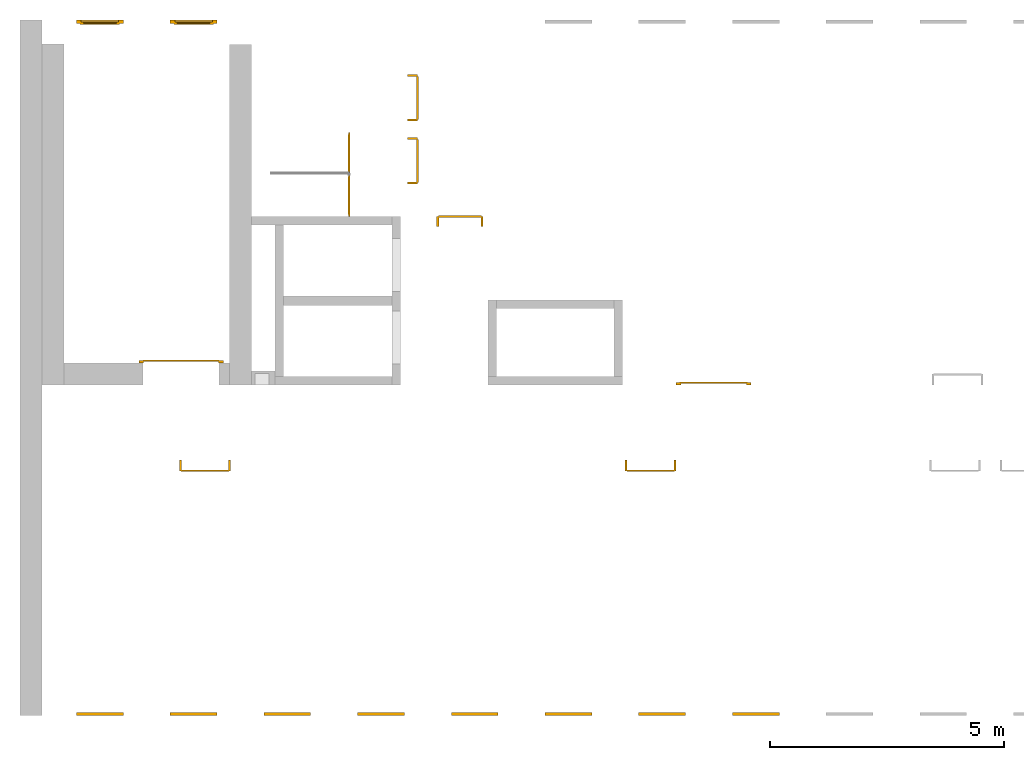
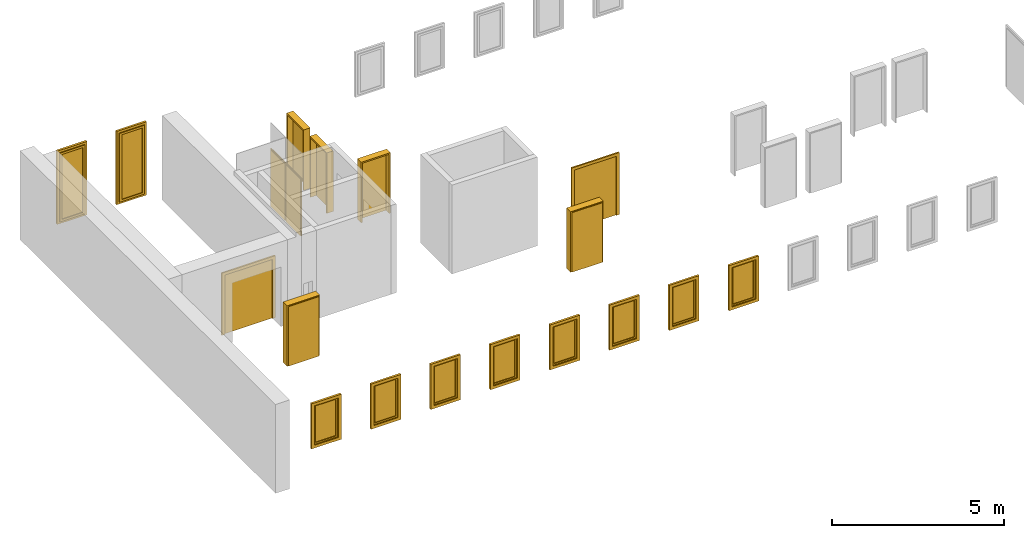
# One storey, part 2 of 3: 10 windows, 9 doors.
"""IFC4 building model written with IfcOpenShell, lengths in metres."""

from ifc_helpers import new_model, entity, si_unit, converted_unit, derived_unit, direction, frame, origin_with_axes, place, context, subcontext, project, spatial, polygons, source, transform, mapped, type_object, element, save


model = new_model("IFC4")

# Units and contexts
model_context = context("Model", 3, precision=1e-05, world=origin_with_axes(), true_north=direction((0.0, 1.0)))
body_context = subcontext(model_context, "Body", "Model", "MODEL_VIEW")
ifc_project = project(units=[si_unit("LENGTHUNIT", "METRE"), si_unit("AREAUNIT", "SQUARE_METRE"), si_unit("VOLUMEUNIT", "CUBIC_METRE"), converted_unit("PLANEANGLEUNIT", "DEGREE", entity("IfcPlaneAngleMeasure", 0.0174532925199433), si_unit("PLANEANGLEUNIT", "RADIAN"), dimensions=[0, 0, 0, 0, 0, 0, 0]), converted_unit("TIMEUNIT", "Year", entity("IfcTimeMeasure", 31557600.0), si_unit("TIMEUNIT", "SECOND"), dimensions=[0, 0, 1, 0, 0, 0, 0]), si_unit("MASSUNIT", "GRAM", prefix="KILO"), si_unit("THERMODYNAMICTEMPERATUREUNIT", "DEGREE_CELSIUS"), si_unit("LUMINOUSINTENSITYUNIT", "LUMEN"), si_unit("ENERGYUNIT", "JOULE", prefix="MEGA"), derived_unit("THERMALCONDUCTANCEUNIT", [(si_unit("POWERUNIT", "WATT"), 1), (si_unit("LENGTHUNIT", "METRE"), -1), (si_unit("THERMODYNAMICTEMPERATUREUNIT", "KELVIN"), -1)]), derived_unit("SPECIFICHEATCAPACITYUNIT", [(si_unit("ENERGYUNIT", "JOULE"), 1), (si_unit("MASSUNIT", "GRAM", prefix="KILO"), -1), (si_unit("THERMODYNAMICTEMPERATUREUNIT", "KELVIN"), -1)]), derived_unit("MASSDENSITYUNIT", [(si_unit("MASSUNIT", "GRAM", prefix="KILO"), 1), (si_unit("VOLUMEUNIT", "CUBIC_METRE"), -1)])], contexts=[model_context])

# Site, building, storey
site_placement = place(None, origin_with_axes())
site = spatial("IfcSite", under=ifc_project, at=site_placement, CompositionType="ELEMENT")
building_placement = place(None, origin_with_axes())
building = spatial("IfcBuilding", under=site, at=building_placement, CompositionType="ELEMENT")
storey_placement = place(None, frame((0.0, 0.0, 10.5), z_axis=(0.0, 0.0, 1.0), x_axis=(1.0, 0.0, 0.0)))
storey = spatial("IfcBuildingStorey", under=building, at=storey_placement, Name="3 OG", CompositionType="ELEMENT", Elevation=10.5)

# Windows
window_type = type_object("IfcWindowType", Name="1-27", PartitioningType="SINGLE_PANEL", PredefinedType="WINDOW")
shared_shape_1 = source(origin_with_axes(), body_context, "Body", "Tessellation", [
    polygons([(-0.5, -0.07, 0.0), (-0.5, 0.0, 0.0), (-0.4, 0.0, 0.1), (-0.4, -0.07, 0.1), (-0.5, -0.07, 1.6), (-0.5, 0.0, 1.6), (-0.4, 0.0, 1.5), (-0.4, -0.07, 1.5)], [[[1, 2, 3, 4]], [[5, 6, 2, 1]], [[2, 6, 7, 3]], [[4, 3, 7, 8]], [[1, 4, 8, 5]], [[8, 7, 6, 5]]], closed=True),
    polygons([(0.5, -0.07, 0.0), (0.5, 0.0, 0.0), (0.5, 0.0, 1.6), (0.5, -0.07, 1.6), (0.4, -0.07, 0.1), (0.4, 0.0, 0.1), (0.4, 0.0, 1.5), (0.4, -0.07, 1.5)], [[[1, 2, 3, 4]], [[5, 6, 2, 1]], [[2, 6, 7, 3]], [[4, 3, 7, 8]], [[1, 4, 8, 5]], [[8, 7, 6, 5]]], closed=True),
    polygons([(-0.5, -0.07, 0.0), (-0.5, 0.0, 0.0), (0.5, 0.0, 0.0), (0.5, -0.07, 0.0), (-0.4, -0.07, 0.1), (-0.4, 0.0, 0.1), (0.0, 0.0, 0.1), (0.4, 0.0, 0.1), (0.4, -0.07, 0.1), (0.0, -0.07, 0.1)], [[[1, 2, 3, 4]], [[5, 6, 2, 1]], [[2, 6, 7, 8, 3]], [[4, 3, 8, 9]], [[1, 4, 9, 10, 5]], [[10, 7, 6, 5]], [[9, 8, 7, 10]]], closed=True),
    polygons([(-0.5, -0.07, 1.6), (-0.5, 0.0, 1.6), (-0.4, 0.0, 1.5), (-0.4, -0.07, 1.5), (0.5, -0.07, 1.6), (0.5, 0.0, 1.6), (0.4, 0.0, 1.5), (0.0, 0.0, 1.5), (0.0, -0.07, 1.5), (0.4, -0.07, 1.5)], [[[1, 2, 3, 4]], [[5, 6, 2, 1]], [[2, 6, 7, 8, 3]], [[4, 3, 8, 9]], [[1, 4, 9, 10, 5]], [[10, 7, 6, 5]], [[9, 8, 7, 10]]], closed=True),
    polygons([(-0.42, 0.0, 0.08), (-0.42, 0.03, 0.08), (-0.35, 0.03, 0.15), (-0.35, 0.0, 0.15), (-0.42, 0.0, 1.52), (-0.42, 0.03, 1.52), (-0.35, 0.03, 1.45), (-0.35, 0.0, 1.45)], [[[1, 2, 3, 4]], [[5, 6, 2, 1]], [[2, 6, 7, 3]], [[4, 3, 7, 8]], [[1, 4, 8, 5]], [[8, 7, 6, 5]]], closed=True),
    polygons([(0.42, 0.0, 0.08), (0.35, 0.0, 0.15), (0.35, 0.03, 0.15), (0.42, 0.03, 0.08), (0.42, 0.0, 1.52), (0.35, 0.0, 1.45), (0.35, 0.03, 1.45), (0.42, 0.03, 1.52)], [[[1, 2, 3, 4]], [[1, 5, 6, 2]], [[2, 6, 7, 3]], [[4, 3, 7, 8]], [[5, 1, 4, 8]], [[6, 5, 8, 7]]], closed=True),
    polygons([(-0.42, 0.0, 0.08), (-0.42, 0.03, 0.08), (0.42, 0.03, 0.08), (0.42, 0.0, 0.08), (-0.35, 0.0, 0.15), (-0.35, 0.03, 0.15), (0.35, 0.03, 0.15), (0.35, 0.0, 0.15)], [[[1, 2, 3, 4]], [[5, 6, 2, 1]], [[2, 6, 7, 3]], [[4, 3, 7, 8]], [[1, 4, 8, 5]], [[8, 7, 6, 5]]], closed=True),
    polygons([(-0.42, 0.0, 1.52), (0.42, 0.0, 1.52), (0.42, 0.03, 1.52), (-0.42, 0.03, 1.52), (-0.35, 0.0, 1.45), (0.35, 0.0, 1.45), (0.35, 0.03, 1.45), (-0.35, 0.03, 1.45)], [[[1, 2, 3, 4]], [[1, 5, 6, 2]], [[2, 6, 7, 3]], [[4, 3, 7, 8]], [[5, 1, 4, 8]], [[6, 5, 8, 7]]], closed=True),
    polygons([(-0.4, -0.03, 0.1), (-0.4, 0.0, 0.1), (-0.35, 0.0, 0.15), (-0.35, -0.03, 0.15), (-0.4, -0.03, 1.5), (-0.4, 0.0, 1.5), (-0.35, 0.0, 1.45), (-0.35, -0.03, 1.45)], [[[1, 2, 3, 4]], [[5, 6, 2, 1]], [[2, 6, 7, 3]], [[4, 3, 7, 8]], [[1, 4, 8, 5]], [[8, 7, 6, 5]]], closed=True),
    polygons([(0.4, -0.03, 0.1), (0.35, -0.03, 0.15), (0.35, 0.0, 0.15), (0.4, 0.0, 0.1), (0.4, -0.03, 1.5), (0.35, -0.03, 1.45), (0.35, 0.0, 1.45), (0.4, 0.0, 1.5)], [[[1, 2, 3, 4]], [[1, 5, 6, 2]], [[2, 6, 7, 3]], [[4, 3, 7, 8]], [[5, 1, 4, 8]], [[6, 5, 8, 7]]], closed=True),
    polygons([(-0.4, -0.03, 0.1), (-0.4, 0.0, 0.1), (0.4, 0.0, 0.1), (0.4, -0.03, 0.1), (-0.35, -0.03, 0.15), (-0.35, 0.0, 0.15), (0.35, 0.0, 0.15), (0.35, -0.03, 0.15)], [[[1, 2, 3, 4]], [[5, 6, 2, 1]], [[2, 6, 7, 3]], [[4, 3, 7, 8]], [[1, 4, 8, 5]], [[8, 7, 6, 5]]], closed=True),
    polygons([(-0.4, -0.03, 1.5), (0.4, -0.03, 1.5), (0.4, 0.0, 1.5), (-0.4, 0.0, 1.5), (-0.35, -0.03, 1.45), (0.35, -0.03, 1.45), (0.35, 0.0, 1.45), (-0.35, 0.0, 1.45)], [[[1, 2, 3, 4]], [[1, 5, 6, 2]], [[2, 6, 7, 3]], [[4, 3, 7, 8]], [[5, 1, 4, 8]], [[6, 5, 8, 7]]], closed=True),
    polygons([(-0.35, -0.00500000000000001, 0.15), (-0.35, 0.00499999999999999, 0.15), (0.35, 0.00499999999999999, 0.15), (0.35, -0.00500000000000001, 0.15), (-0.35, -0.00500000000000001, 1.45), (-0.35, 0.00499999999999999, 1.45), (0.35, 0.00499999999999999, 1.45), (0.35, -0.00500000000000001, 1.45)], [[[1, 2, 3, 4]], [[5, 6, 2, 1]], [[2, 6, 7, 3]], [[4, 3, 7, 8]], [[1, 4, 8, 5]], [[8, 7, 6, 5]]], closed=True),
])
window_1_placement = place(None, frame((32.723, 0.0, 11.5), z_axis=(0.0, 0.0, 1.0), x_axis=(1.0, 0.0, 0.0)))
element("IfcWindow", 1, at=window_1_placement, inside=storey, type_object=window_type, Name="Fenster-001", OverallHeight=1.6, OverallWidth=1.0, context=body_context, shape_type="MappedRepresentation", body=[
    mapped(shared_shape_1, transform((0.5, 0.0700000000000033, 0.0))),
])
window_2_placement = place(None, frame((28.723, 0.0, 11.5), z_axis=(0.0, 0.0, 1.0), x_axis=(1.0, 0.0, 0.0)))
element("IfcWindow", 2, at=window_2_placement, inside=storey, type_object=window_type, Name="Fenster-001", OverallHeight=1.6, OverallWidth=1.0, context=body_context, shape_type="MappedRepresentation", body=[
    mapped(shared_shape_1, transform((0.5, 0.0700000000000037, 0.0))),
])
window_3_placement = place(None, frame((26.723, 0.0, 11.5), z_axis=(0.0, 0.0, 1.0), x_axis=(1.0, 0.0, 0.0)))
element("IfcWindow", 3, at=window_3_placement, inside=storey, type_object=window_type, Name="Fenster-001", OverallHeight=1.6, OverallWidth=1.0, context=body_context, shape_type="MappedRepresentation", body=[
    mapped(shared_shape_1, transform((0.5, 0.0700000000000041, 0.0))),
])
window_4_placement = place(None, frame((30.723, 0.0, 11.5), z_axis=(0.0, 0.0, 1.0), x_axis=(1.0, 0.0, 0.0)))
element("IfcWindow", 4, at=window_4_placement, inside=storey, type_object=window_type, Name="Fenster-001", OverallHeight=1.6, OverallWidth=1.0, context=body_context, shape_type="MappedRepresentation", body=[
    mapped(shared_shape_1, transform((0.5, 0.0700000000000035, 0.0))),
])
window_5_placement = place(None, frame((38.723, 0.0, 11.5), z_axis=(0.0, 0.0, 1.0), x_axis=(1.0, 0.0, 0.0)))
element("IfcWindow", 5, at=window_5_placement, inside=storey, type_object=window_type, Name="Fenster-001", OverallHeight=1.6, OverallWidth=1.0, context=body_context, shape_type="MappedRepresentation", body=[
    mapped(shared_shape_1, transform((0.5, 0.0700000000000025, 0.0))),
])
window_6_placement = place(None, frame((34.723, 0.0, 11.5), z_axis=(0.0, 0.0, 1.0), x_axis=(1.0, 0.0, 0.0)))
element("IfcWindow", 6, at=window_6_placement, inside=storey, type_object=window_type, Name="Fenster-001", OverallHeight=1.6, OverallWidth=1.0, context=body_context, shape_type="MappedRepresentation", body=[
    mapped(shared_shape_1, transform((0.5, 0.0700000000000031, 0.0))),
])
window_7_placement = place(None, frame((24.723, 0.0, 11.5), z_axis=(0.0, 0.0, 1.0), x_axis=(1.0, 0.0, 0.0)))
element("IfcWindow", 7, at=window_7_placement, inside=storey, type_object=window_type, Name="Fenster-001", OverallHeight=1.6, OverallWidth=1.0, context=body_context, shape_type="MappedRepresentation", body=[
    mapped(shared_shape_1, transform((0.5, 0.0700000000000043, 0.0))),
])
window_8_placement = place(None, frame((36.723, 0.0, 11.5), z_axis=(0.0, 0.0, 1.0), x_axis=(1.0, 0.0, 0.0)))
element("IfcWindow", 8, at=window_8_placement, inside=storey, type_object=window_type, Name="Fenster-001", OverallHeight=1.6, OverallWidth=1.0, context=body_context, shape_type="MappedRepresentation", body=[
    mapped(shared_shape_1, transform((0.5, 0.0700000000000028, 0.0))),
])

# Doors
door_type_1 = type_object("IfcDoorType", Name="27", OperationType="SINGLE_SWING_RIGHT", PredefinedType="DOOR")
shared_shape_2 = source(origin_with_axes(), body_context, "Body", "Tessellation", [
    polygons([(0.545, -0.2325, 0.0), (0.545, -0.025, 0.0), (0.545, -0.025, 2.145), (0.545, -0.2325, 2.145), (0.5, -0.2325, 0.0), (0.5, -0.025, 0.0), (0.5, -0.025, 2.1), (0.0551, -0.025, 2.1), (0.0001, -0.025, 2.1), (-0.5, -0.025, 2.1), (-0.5, -0.025, 0.0), (-0.545, -0.025, 0.0), (-0.545, -0.025, 2.145), (-0.545, -0.2325, 2.145), (-0.545, -0.2325, 0.0), (-0.5, -0.2325, 0.0), (-0.5, -0.2325, 2.1), (0.0001, -0.2325, 2.1), (0.0551, -0.2325, 2.1), (0.5, -0.2325, 2.1)], [[[1, 2, 3, 4]], [[5, 6, 2, 1]], [[2, 6, 7, 8, 9, 10, 11, 12, 13, 3]], [[4, 3, 13, 14]], [[1, 4, 14, 15, 16, 17, 18, 19, 20, 5]], [[20, 7, 6, 5]], [[19, 8, 7, 20]], [[18, 9, 8, 19]], [[17, 10, 9, 18]], [[16, 11, 10, 17]], [[15, 12, 11, 16]], [[14, 13, 12, 15]]], closed=True),
    polygons([(0.545, -0.025, 0.0), (0.545, 0.0, 0.0), (0.545, 0.0, 2.145), (0.545, -0.025, 2.145), (0.51, -0.025, 0.0), (0.51, 0.0, 0.0), (0.51, 0.0, 2.11), (0.0451, 0.0, 2.11), (0.0101, 0.0, 2.11), (-0.51, 0.0, 2.11), (-0.51, 0.0, 0.0), (-0.545, 0.0, 0.0), (-0.545, 0.0, 2.145), (-0.545, -0.025, 2.145), (-0.545, -0.025, 0.0), (-0.51, -0.025, 0.0), (-0.51, -0.025, 2.11), (0.0101, -0.025, 2.11), (0.0451, -0.025, 2.11), (0.51, -0.025, 2.11)], [[[1, 2, 3, 4]], [[5, 6, 2, 1]], [[2, 6, 7, 8, 9, 10, 11, 12, 13, 3]], [[4, 3, 13, 14]], [[1, 4, 14, 15, 16, 17, 18, 19, 20, 5]], [[20, 7, 6, 5]], [[19, 8, 7, 20]], [[18, 9, 8, 19]], [[17, 10, 9, 18]], [[16, 11, 10, 17]], [[15, 12, 11, 16]], [[14, 13, 12, 15]]], closed=True),
    polygons([(0.51, 0.015, 0.0), (-0.51, 0.015, 0.0), (-0.51, 0.015, 2.11), (0.51, 0.015, 2.11), (0.51, -0.025, 0.0), (-0.51, -0.025, 0.0), (-0.51, -0.025, 2.11), (0.51, -0.025, 2.11)], [[[1, 2, 3, 4]], [[2, 1, 5, 6]], [[3, 2, 6, 7]], [[4, 3, 7, 8]], [[1, 4, 8, 5]], [[6, 5, 8, 7]]], closed=True),
])
door_1_placement = place(None, frame((37.477, 5.45499994546755, 10.5), z_axis=(0.0, 0.0, 1.0), x_axis=(-1.0, 0.0, 0.0)))
element("IfcDoor", 9, at=door_1_placement, inside=storey, type_object=door_type_1, OverallHeight=2.145, OverallWidth=1.09, context=body_context, shape_type="MappedRepresentation", body=[
    mapped(shared_shape_2, transform((0.5, 0.2325, 0.0))),
])
door_type_2 = type_object("IfcDoorType", Name="27", OperationType="SINGLE_SWING_LEFT", PredefinedType="DOOR")
shared_shape_3 = source(origin_with_axes(), body_context, "Body", "Tessellation", [
    polygons([(-0.445, -0.025, 0.0), (-0.445, -0.025, 2.045), (-0.445, 0.0, 2.045), (-0.445, 0.0, 0.0), (-0.41, -0.025, 0.0), (-0.41, -0.025, 2.01), (-0.0451, -0.025, 2.01), (-0.0101, -0.025, 2.01), (0.41, -0.025, 2.01), (0.41, -0.025, 0.0), (0.445, -0.025, 0.0), (0.445, -0.025, 2.045), (0.445, 0.0, 2.045), (0.445, 0.0, 0.0), (0.41, 0.0, 0.0), (0.41, 0.0, 2.01), (-0.0101, 0.0, 2.01), (-0.0451, 0.0, 2.01), (-0.41, 0.0, 2.01), (-0.41, 0.0, 0.0)], [[[1, 2, 3, 4]], [[1, 5, 6, 7, 8, 9, 10, 11, 12, 2]], [[2, 12, 13, 3]], [[4, 3, 13, 14, 15, 16, 17, 18, 19, 20]], [[5, 1, 4, 20]], [[6, 5, 20, 19]], [[7, 6, 19, 18]], [[8, 7, 18, 17]], [[9, 8, 17, 16]], [[10, 9, 16, 15]], [[11, 10, 15, 14]], [[12, 11, 14, 13]]], closed=True),
    polygons([(-0.41, 0.015, 0.0), (-0.41, 0.015, 2.01), (0.41, 0.015, 2.01), (0.41, 0.015, 0.0), (-0.41, -0.025, 0.0), (-0.41, -0.025, 2.01), (0.41, -0.025, 2.01), (0.41, -0.025, 0.0)], [[[1, 2, 3, 4]], [[1, 5, 6, 2]], [[2, 6, 7, 3]], [[3, 7, 8, 4]], [[4, 8, 5, 1]], [[8, 7, 6, 5]]], closed=True),
])
door_2_placement = place(None, frame((30.553, 10.6999999454675, 10.55), z_axis=(0.0, 0.0, 1.0), x_axis=(0.0, 1.0, 0.0)))
element("IfcDoor", 10, at=door_2_placement, inside=storey, type_object=door_type_2, OverallHeight=2.095, OverallWidth=0.89, context=body_context, shape_type="MappedRepresentation", body=[
    mapped(shared_shape_3, transform((0.4, 0.0199999999999996, 0.0))),
])
door_type_3 = type_object("IfcDoorType", Name="2-Fl 27", OperationType="DOUBLE_DOOR_SINGLE_SWING", PredefinedType="DOOR")
shared_shape_4 = source(origin_with_axes(), body_context, "Body", "Tessellation", [
    polygons([(0.8, -0.05, 0.0), (0.8, -0.02, 0.0), (0.8, -0.02, 2.2), (0.8, -0.05, 2.2), (0.7, -0.05, 0.0), (0.7, -0.02, 0.0), (0.7, -0.02, 2.1), (0.1251, -0.02, 2.1), (0.0001, -0.02, 2.1), (-0.7, -0.02, 2.1), (-0.7, -0.02, 0.0), (-0.8, -0.02, 0.0), (-0.8, -0.02, 2.2), (-0.8, -0.05, 2.2), (-0.8, -0.05, 0.0), (-0.7, -0.05, 0.0), (-0.7, -0.05, 2.1), (0.0001, -0.05, 2.1), (0.1251, -0.05, 2.1), (0.7, -0.05, 2.1)], [[[1, 2, 3, 4]], [[5, 6, 2, 1]], [[2, 6, 7, 8, 9, 10, 11, 12, 13, 3]], [[4, 3, 13, 14]], [[1, 4, 14, 15, 16, 17, 18, 19, 20, 5]], [[20, 7, 6, 5]], [[19, 8, 7, 20]], [[18, 9, 8, 19]], [[17, 10, 9, 18]], [[16, 11, 10, 17]], [[15, 12, 11, 16]], [[14, 13, 12, 15]]], closed=True),
    polygons([(0.8, -0.02, 0.0), (0.8, 0.0, 0.0), (0.8, 0.0, 2.2), (0.8, -0.02, 2.2), (0.725, -0.02, 0.0), (0.725, 0.0, 0.0), (0.725, 0.0, 2.125), (0.1001, 0.0, 2.125), (0.0251, 0.0, 2.125), (-0.725, 0.0, 2.125), (-0.725, 0.0, 0.0), (-0.8, 0.0, 0.0), (-0.8, 0.0, 2.2), (-0.8, -0.02, 2.2), (-0.8, -0.02, 0.0), (-0.725, -0.02, 0.0), (-0.725, -0.02, 2.125), (0.0251, -0.02, 2.125), (0.1001, -0.02, 2.125), (0.725, -0.02, 2.125)], [[[1, 2, 3, 4]], [[5, 6, 2, 1]], [[2, 6, 7, 8, 9, 10, 11, 12, 13, 3]], [[4, 3, 13, 14]], [[1, 4, 14, 15, 16, 17, 18, 19, 20, 5]], [[20, 7, 6, 5]], [[19, 8, 7, 20]], [[18, 9, 8, 19]], [[17, 10, 9, 18]], [[16, 11, 10, 17]], [[15, 12, 11, 16]], [[14, 13, 12, 15]]], closed=True),
    polygons([(0.725, 0.02, 0.0), (0.000499999999999945, 0.02, 0.0), (0.000499999999999945, 0.02, 2.125), (0.725, 0.02, 2.125), (0.725, -0.02, 0.0), (0.000499999999999945, -0.02, 0.0), (0.000499999999999945, -0.02, 2.125), (0.725, -0.02, 2.125)], [[[1, 2, 3, 4]], [[2, 1, 5, 6]], [[3, 2, 6, 7]], [[4, 3, 7, 8]], [[1, 4, 8, 5]], [[6, 5, 8, 7]]], closed=True),
    polygons([(-0.725, 0.02, 0.0), (-0.725, 0.02, 2.125), (-0.000499999999999945, 0.02, 2.125), (-0.000499999999999945, 0.02, 0.0), (-0.725, -0.02, 0.0), (-0.725, -0.02, 2.125), (-0.000499999999999945, -0.02, 2.125), (-0.000499999999999945, -0.02, 0.0)], [[[1, 2, 3, 4]], [[1, 5, 6, 2]], [[2, 6, 7, 3]], [[3, 7, 8, 4]], [[4, 8, 5, 1]], [[8, 7, 6, 5]]], closed=True),
])
door_3_placement = place(None, frame((37.622, 7.05499994546756, 10.5), z_axis=(0.0, 0.0, 1.0), x_axis=(1.0, 0.0, 0.0)))
element("IfcDoor", 11, at=door_3_placement, inside=storey, type_object=door_type_3, OverallHeight=2.2, OverallWidth=1.6, context=body_context, shape_type="MappedRepresentation", body=[
    mapped(shared_shape_4, transform((0.700000000000003, 0.0499999999999998, 0.0))),
])
door_type_4 = type_object("IfcDoorType", OperationType="DOUBLE_DOOR_SINGLE_SWING", PredefinedType="DOOR")
shared_shape_5 = source(origin_with_axes(), body_context, "Body", "Tessellation", [
    polygons([(0.9, 0.0, 0.0), (0.9, 0.03, 0.0), (0.9, 0.03, 2.2), (0.9, 0.0, 2.2), (0.8, 0.0, 0.0), (0.8, 0.03, 0.0), (0.8, 0.03, 2.1), (0.1101, 0.03, 2.1), (0.0001, 0.03, 2.1), (-0.8, 0.03, 2.1), (-0.8, 0.03, 0.0), (-0.9, 0.03, 0.0), (-0.9, 0.03, 2.2), (-0.9, 0.0, 2.2), (-0.9, 0.0, 0.0), (-0.8, 0.0, 0.0), (-0.8, 0.0, 2.1), (0.0001, 0.0, 2.1), (0.1101, 0.0, 2.1), (0.8, 0.0, 2.1)], [[[1, 2, 3, 4]], [[5, 6, 2, 1]], [[2, 6, 7, 8, 9, 10, 11, 12, 13, 3]], [[4, 3, 13, 14]], [[1, 4, 14, 15, 16, 17, 18, 19, 20, 5]], [[20, 7, 6, 5]], [[19, 8, 7, 20]], [[18, 9, 8, 19]], [[17, 10, 9, 18]], [[16, 11, 10, 17]], [[15, 12, 11, 16]], [[14, 13, 12, 15]]], closed=True),
    polygons([(0.9, 0.03, 0.0), (0.9, 0.05, 0.0), (0.9, 0.05, 2.2), (0.9, 0.03, 2.2), (0.81, 0.03, 0.0), (0.81, 0.05, 0.0), (0.81, 0.05, 2.11), (0.1001, 0.05, 2.11), (0.0101, 0.05, 2.11), (-0.81, 0.05, 2.11), (-0.81, 0.05, 0.0), (-0.9, 0.05, 0.0), (-0.9, 0.05, 2.2), (-0.9, 0.03, 2.2), (-0.9, 0.03, 0.0), (-0.81, 0.03, 0.0), (-0.81, 0.03, 2.11), (0.0101, 0.03, 2.11), (0.1001, 0.03, 2.11), (0.81, 0.03, 2.11)], [[[1, 2, 3, 4]], [[5, 6, 2, 1]], [[2, 6, 7, 8, 9, 10, 11, 12, 13, 3]], [[4, 3, 13, 14]], [[1, 4, 14, 15, 16, 17, 18, 19, 20, 5]], [[20, 7, 6, 5]], [[19, 8, 7, 20]], [[18, 9, 8, 19]], [[17, 10, 9, 18]], [[16, 11, 10, 17]], [[15, 12, 11, 16]], [[14, 13, 12, 15]]], closed=True),
    polygons([(0.81, 0.07, 0.0), (0.000499999999999945, 0.07, 0.0), (0.000499999999999945, 0.07, 2.11), (0.81, 0.07, 2.11), (0.81, 0.03, 0.0), (0.000499999999999945, 0.03, 0.0), (0.000499999999999945, 0.03, 2.11), (0.81, 0.03, 2.11)], [[[1, 2, 3, 4]], [[2, 1, 5, 6]], [[3, 2, 6, 7]], [[4, 3, 7, 8]], [[1, 4, 8, 5]], [[6, 5, 8, 7]]], closed=True),
    polygons([(-0.81, 0.07, 0.0), (-0.81, 0.07, 2.11), (-0.000499999999999945, 0.07, 2.11), (-0.000499999999999945, 0.07, 0.0), (-0.81, 0.03, 0.0), (-0.81, 0.03, 2.11), (-0.000499999999999945, 0.03, 2.11), (-0.000499999999999945, 0.03, 0.0)], [[[1, 2, 3, 4]], [[1, 5, 6, 2]], [[2, 6, 7, 3]], [[3, 7, 8, 4]], [[4, 8, 5, 1]], [[8, 7, 6, 5]]], closed=True),
])
door_4_placement = place(None, frame((26.158, 7.52499994546755, 10.5), z_axis=(0.0, 0.0, 1.0), x_axis=(1.0, 0.0, 0.0)))
element("IfcDoor", 12, at=door_4_placement, inside=storey, type_object=door_type_4, OverallHeight=2.11, OverallWidth=1.62, context=body_context, shape_type="MappedRepresentation", body=[
    mapped(shared_shape_5, transform((0.800000000000001, 0.0, 0.0))),
])
shared_shape_6 = source(origin_with_axes(), body_context, "Body", "Tessellation", [
    polygons([(-0.495, -0.218, 0.0), (-0.495, -0.218, 2.145), (-0.495, -0.025, 2.145), (-0.495, -0.025, 0.0), (-0.45, -0.218, 0.0), (-0.45, -0.218, 2.1), (-0.0551, -0.218, 2.1), (-0.0001, -0.218, 2.1), (0.45, -0.218, 2.1), (0.45, -0.218, 0.0), (0.495, -0.218, 0.0), (0.495, -0.218, 2.145), (0.495, -0.025, 2.145), (0.495, -0.025, 0.0), (0.45, -0.025, 0.0), (0.45, -0.025, 2.1), (-0.0001, -0.025, 2.1), (-0.0551, -0.025, 2.1), (-0.45, -0.025, 2.1), (-0.45, -0.025, 0.0)], [[[1, 2, 3, 4]], [[1, 5, 6, 7, 8, 9, 10, 11, 12, 2]], [[2, 12, 13, 3]], [[4, 3, 13, 14, 15, 16, 17, 18, 19, 20]], [[5, 1, 4, 20]], [[6, 5, 20, 19]], [[7, 6, 19, 18]], [[8, 7, 18, 17]], [[9, 8, 17, 16]], [[10, 9, 16, 15]], [[11, 10, 15, 14]], [[12, 11, 14, 13]]], closed=True),
    polygons([(-0.495, -0.025, 0.0), (-0.495, -0.025, 2.145), (-0.495, 0.0, 2.145), (-0.495, 0.0, 0.0), (-0.46, -0.025, 0.0), (-0.46, -0.025, 2.11), (-0.0451, -0.025, 2.11), (-0.0101, -0.025, 2.11), (0.46, -0.025, 2.11), (0.46, -0.025, 0.0), (0.495, -0.025, 0.0), (0.495, -0.025, 2.145), (0.495, 0.0, 2.145), (0.495, 0.0, 0.0), (0.46, 0.0, 0.0), (0.46, 0.0, 2.11), (-0.0101, 0.0, 2.11), (-0.0451, 0.0, 2.11), (-0.46, 0.0, 2.11), (-0.46, 0.0, 0.0)], [[[1, 2, 3, 4]], [[1, 5, 6, 7, 8, 9, 10, 11, 12, 2]], [[2, 12, 13, 3]], [[4, 3, 13, 14, 15, 16, 17, 18, 19, 20]], [[5, 1, 4, 20]], [[6, 5, 20, 19]], [[7, 6, 19, 18]], [[8, 7, 18, 17]], [[9, 8, 17, 16]], [[10, 9, 16, 15]], [[11, 10, 15, 14]], [[12, 11, 14, 13]]], closed=True),
    polygons([(-0.46, 0.015, 0.0), (-0.46, 0.015, 2.11), (0.46, 0.015, 2.11), (0.46, 0.015, 0.0), (-0.46, -0.025, 0.0), (-0.46, -0.025, 2.11), (0.46, -0.025, 2.11), (0.46, -0.025, 0.0)], [[[1, 2, 3, 4]], [[1, 5, 6, 2]], [[2, 6, 7, 3]], [[3, 7, 8, 4]], [[4, 8, 5, 1]], [[8, 7, 6, 5]]], closed=True),
])
for number, where, z_axis, x_axis in (
    (13, (32.005, 13.6354999136732, 10.5), (0.0, 0.0, 1.0), (0.0, -1.0, 0.0)),
    (14, (32.005, 12.2904999136732, 10.5), (0.0, 0.0, 1.0), (0.0, -1.0, 0.0)),
):
    element("IfcDoor", number, at=place(None, frame(where, z_axis=z_axis, x_axis=x_axis)), inside=storey, type_object=door_type_2, OverallHeight=2.145, OverallWidth=0.99, context=body_context, shape_type="MappedRepresentation", body=[
        mapped(shared_shape_6, transform((0.449999999999999, 0.0, 0.0))),
    ])
shared_shape_7 = source(origin_with_axes(), body_context, "Body", "Tessellation", [
    polygons([(0.445, -0.025, 0.0), (0.445, 0.0, 0.0), (0.445, 0.0, 2.045), (0.445, -0.025, 2.045), (0.41, -0.025, 0.0), (0.41, 0.0, 0.0), (0.41, 0.0, 2.01), (0.0451, 0.0, 2.01), (0.0101, 0.0, 2.01), (-0.41, 0.0, 2.01), (-0.41, 0.0, 0.0), (-0.445, 0.0, 0.0), (-0.445, 0.0, 2.045), (-0.445, -0.025, 2.045), (-0.445, -0.025, 0.0), (-0.41, -0.025, 0.0), (-0.41, -0.025, 2.01), (0.0101, -0.025, 2.01), (0.0451, -0.025, 2.01), (0.41, -0.025, 2.01)], [[[1, 2, 3, 4]], [[5, 6, 2, 1]], [[2, 6, 7, 8, 9, 10, 11, 12, 13, 3]], [[4, 3, 13, 14]], [[1, 4, 14, 15, 16, 17, 18, 19, 20, 5]], [[20, 7, 6, 5]], [[19, 8, 7, 20]], [[18, 9, 8, 19]], [[17, 10, 9, 18]], [[16, 11, 10, 17]], [[15, 12, 11, 16]], [[14, 13, 12, 15]]], closed=True),
    polygons([(0.41, 0.015, 0.0), (-0.41, 0.015, 0.0), (-0.41, 0.015, 2.01), (0.41, 0.015, 2.01), (0.41, -0.025, 0.0), (-0.41, -0.025, 0.0), (-0.41, -0.025, 2.01), (0.41, -0.025, 2.01)], [[[1, 2, 3, 4]], [[2, 1, 5, 6]], [[3, 2, 6, 7]], [[4, 3, 7, 8]], [[1, 4, 8, 5]], [[6, 5, 8, 7]]], closed=True),
])
door_5_placement = place(None, frame((30.553, 11.5954999136732, 10.55), z_axis=(0.0, 0.0, 1.0), x_axis=(0.0, 1.0, 0.0)))
element("IfcDoor", 15, at=door_5_placement, inside=storey, type_object=door_type_1, OverallHeight=2.095, OverallWidth=0.89, context=body_context, shape_type="MappedRepresentation", body=[
    mapped(shared_shape_7, transform((0.4, 0.0199999999999996, 0.0))),
])
shared_shape_8 = source(origin_with_axes(), body_context, "Body", "Tessellation", [
    polygons([(0.495, -0.218, 0.0), (0.495, -0.025, 0.0), (0.495, -0.025, 2.145), (0.495, -0.218, 2.145), (0.45, -0.218, 0.0), (0.45, -0.025, 0.0), (0.45, -0.025, 2.1), (0.0551, -0.025, 2.1), (0.0001, -0.025, 2.1), (-0.45, -0.025, 2.1), (-0.45, -0.025, 0.0), (-0.495, -0.025, 0.0), (-0.495, -0.025, 2.145), (-0.495, -0.218, 2.145), (-0.495, -0.218, 0.0), (-0.45, -0.218, 0.0), (-0.45, -0.218, 2.1), (0.0001, -0.218, 2.1), (0.0551, -0.218, 2.1), (0.45, -0.218, 2.1)], [[[1, 2, 3, 4]], [[5, 6, 2, 1]], [[2, 6, 7, 8, 9, 10, 11, 12, 13, 3]], [[4, 3, 13, 14]], [[1, 4, 14, 15, 16, 17, 18, 19, 20, 5]], [[20, 7, 6, 5]], [[19, 8, 7, 20]], [[18, 9, 8, 19]], [[17, 10, 9, 18]], [[16, 11, 10, 17]], [[15, 12, 11, 16]], [[14, 13, 12, 15]]], closed=True),
    polygons([(0.495, -0.025, 0.0), (0.495, 0.0, 0.0), (0.495, 0.0, 2.145), (0.495, -0.025, 2.145), (0.46, -0.025, 0.0), (0.46, 0.0, 0.0), (0.46, 0.0, 2.11), (0.0451, 0.0, 2.11), (0.0101, 0.0, 2.11), (-0.46, 0.0, 2.11), (-0.46, 0.0, 0.0), (-0.495, 0.0, 0.0), (-0.495, 0.0, 2.145), (-0.495, -0.025, 2.145), (-0.495, -0.025, 0.0), (-0.46, -0.025, 0.0), (-0.46, -0.025, 2.11), (0.0101, -0.025, 2.11), (0.0451, -0.025, 2.11), (0.46, -0.025, 2.11)], [[[1, 2, 3, 4]], [[5, 6, 2, 1]], [[2, 6, 7, 8, 9, 10, 11, 12, 13, 3]], [[4, 3, 13, 14]], [[1, 4, 14, 15, 16, 17, 18, 19, 20, 5]], [[20, 7, 6, 5]], [[19, 8, 7, 20]], [[18, 9, 8, 19]], [[17, 10, 9, 18]], [[16, 11, 10, 17]], [[15, 12, 11, 16]], [[14, 13, 12, 15]]], closed=True),
    polygons([(0.46, 0.015, 0.0), (-0.46, 0.015, 0.0), (-0.46, 0.015, 2.11), (0.46, 0.015, 2.11), (0.46, -0.025, 0.0), (-0.46, -0.025, 0.0), (-0.46, -0.025, 2.11), (0.46, -0.025, 2.11)], [[[1, 2, 3, 4]], [[2, 1, 5, 6]], [[3, 2, 6, 7]], [[4, 3, 7, 8]], [[1, 4, 8, 5]], [[6, 5, 8, 7]]], closed=True),
])
door_6_placement = place(None, frame((32.455, 10.6549999454676, 10.5), z_axis=(0.0, 0.0, 1.0), x_axis=(1.0, 0.0, 0.0)))
element("IfcDoor", 16, at=door_6_placement, inside=storey, type_object=door_type_1, OverallHeight=2.145, OverallWidth=0.99, context=body_context, shape_type="MappedRepresentation", body=[
    mapped(shared_shape_8, transform((0.450000000000003, 0.0, 0.0))),
])
shared_shape_9 = source(origin_with_axes(), body_context, "Body", "Tessellation", [
    polygons([(-0.545, -0.2325, 0.0), (-0.545, -0.2325, 2.145), (-0.545, -0.025, 2.145), (-0.545, -0.025, 0.0), (-0.5, -0.2325, 0.0), (-0.5, -0.2325, 2.1), (-0.0551, -0.2325, 2.1), (-0.0001, -0.2325, 2.1), (0.5, -0.2325, 2.1), (0.5, -0.2325, 0.0), (0.545, -0.2325, 0.0), (0.545, -0.2325, 2.145), (0.545, -0.025, 2.145), (0.545, -0.025, 0.0), (0.5, -0.025, 0.0), (0.5, -0.025, 2.1), (-0.0001, -0.025, 2.1), (-0.0551, -0.025, 2.1), (-0.5, -0.025, 2.1), (-0.5, -0.025, 0.0)], [[[1, 2, 3, 4]], [[1, 5, 6, 7, 8, 9, 10, 11, 12, 2]], [[2, 12, 13, 3]], [[4, 3, 13, 14, 15, 16, 17, 18, 19, 20]], [[5, 1, 4, 20]], [[6, 5, 20, 19]], [[7, 6, 19, 18]], [[8, 7, 18, 17]], [[9, 8, 17, 16]], [[10, 9, 16, 15]], [[11, 10, 15, 14]], [[12, 11, 14, 13]]], closed=True),
    polygons([(-0.545, -0.025, 0.0), (-0.545, -0.025, 2.145), (-0.545, 0.0, 2.145), (-0.545, 0.0, 0.0), (-0.51, -0.025, 0.0), (-0.51, -0.025, 2.11), (-0.0451, -0.025, 2.11), (-0.0101, -0.025, 2.11), (0.51, -0.025, 2.11), (0.51, -0.025, 0.0), (0.545, -0.025, 0.0), (0.545, -0.025, 2.145), (0.545, 0.0, 2.145), (0.545, 0.0, 0.0), (0.51, 0.0, 0.0), (0.51, 0.0, 2.11), (-0.0101, 0.0, 2.11), (-0.0451, 0.0, 2.11), (-0.51, 0.0, 2.11), (-0.51, 0.0, 0.0)], [[[1, 2, 3, 4]], [[1, 5, 6, 7, 8, 9, 10, 11, 12, 2]], [[2, 12, 13, 3]], [[4, 3, 13, 14, 15, 16, 17, 18, 19, 20]], [[5, 1, 4, 20]], [[6, 5, 20, 19]], [[7, 6, 19, 18]], [[8, 7, 18, 17]], [[9, 8, 17, 16]], [[10, 9, 16, 15]], [[11, 10, 15, 14]], [[12, 11, 14, 13]]], closed=True),
    polygons([(-0.51, 0.015, 0.0), (-0.51, 0.015, 2.11), (0.51, 0.015, 2.11), (0.51, 0.015, 0.0), (-0.51, -0.025, 0.0), (-0.51, -0.025, 2.11), (0.51, -0.025, 2.11), (0.51, -0.025, 0.0)], [[[1, 2, 3, 4]], [[1, 5, 6, 2]], [[2, 6, 7, 3]], [[3, 7, 8, 4]], [[4, 8, 5, 1]], [[8, 7, 6, 5]]], closed=True),
])
door_7_placement = place(None, frame((27.969, 5.45499994546755, 10.5), z_axis=(0.0, 0.0, 1.0), x_axis=(-1.0, 0.0, 0.0)))
element("IfcDoor", 17, at=door_7_placement, inside=storey, type_object=door_type_2, OverallHeight=2.145, OverallWidth=1.09, context=body_context, shape_type="MappedRepresentation", body=[
    mapped(shared_shape_9, transform((0.5, 0.2325, 0.0))),
])

# Windows
shared_shape_10 = source(origin_with_axes(), body_context, "Body", "Tessellation", [
    polygons([(0.5, -0.07, 0.0), (0.4, -0.07, 0.1), (0.4, 0.0, 0.1), (0.5, 0.0, 0.0), (0.5, -0.07, 2.6), (0.4, -0.07, 2.5), (0.4, 0.0, 2.5), (0.5, 0.0, 2.6)], [[[1, 2, 3, 4]], [[1, 5, 6, 2]], [[2, 6, 7, 3]], [[4, 3, 7, 8]], [[5, 1, 4, 8]], [[6, 5, 8, 7]]], closed=True),
    polygons([(-0.5, -0.07, 0.0), (-0.5, -0.07, 2.6), (-0.5, 0.0, 2.6), (-0.5, 0.0, 0.0), (-0.4, -0.07, 0.1), (-0.4, -0.07, 2.5), (-0.4, 0.0, 2.5), (-0.4, 0.0, 0.1)], [[[1, 2, 3, 4]], [[1, 5, 6, 2]], [[2, 6, 7, 3]], [[4, 3, 7, 8]], [[5, 1, 4, 8]], [[6, 5, 8, 7]]], closed=True),
    polygons([(0.5, -0.07, 0.0), (-0.5, -0.07, 0.0), (-0.5, 0.0, 0.0), (0.5, 0.0, 0.0), (0.4, -0.07, 0.1), (0.0, -0.07, 0.1), (-0.4, -0.07, 0.1), (-0.4, 0.0, 0.1), (0.0, 0.0, 0.1), (0.4, 0.0, 0.1)], [[[1, 2, 3, 4]], [[1, 5, 6, 7, 2]], [[2, 7, 8, 3]], [[4, 3, 8, 9, 10]], [[5, 1, 4, 10]], [[6, 5, 10, 9]], [[7, 6, 9, 8]]], closed=True),
    polygons([(0.5, -0.07, 2.6), (0.4, -0.07, 2.5), (0.4, 0.0, 2.5), (0.5, 0.0, 2.6), (-0.5, -0.07, 2.6), (-0.4, -0.07, 2.5), (0.0, -0.07, 2.5), (0.0, 0.0, 2.5), (-0.4, 0.0, 2.5), (-0.5, 0.0, 2.6)], [[[1, 2, 3, 4]], [[1, 5, 6, 7, 2]], [[2, 7, 8, 3]], [[4, 3, 8, 9, 10]], [[5, 1, 4, 10]], [[6, 5, 10, 9]], [[7, 6, 9, 8]]], closed=True),
    polygons([(0.42, 0.0, 0.08), (0.35, 0.0, 0.15), (0.35, 0.03, 0.15), (0.42, 0.03, 0.08), (0.42, 0.0, 2.52), (0.35, 0.0, 2.45), (0.35, 0.03, 2.45), (0.42, 0.03, 2.52)], [[[1, 2, 3, 4]], [[1, 5, 6, 2]], [[2, 6, 7, 3]], [[4, 3, 7, 8]], [[5, 1, 4, 8]], [[6, 5, 8, 7]]], closed=True),
    polygons([(-0.42, 0.0, 0.08), (-0.42, 0.03, 0.08), (-0.35, 0.03, 0.15), (-0.35, 0.0, 0.15), (-0.42, 0.0, 2.52), (-0.42, 0.03, 2.52), (-0.35, 0.03, 2.45), (-0.35, 0.0, 2.45)], [[[1, 2, 3, 4]], [[5, 6, 2, 1]], [[2, 6, 7, 3]], [[4, 3, 7, 8]], [[1, 4, 8, 5]], [[8, 7, 6, 5]]], closed=True),
    polygons([(0.42, 0.0, 0.08), (-0.42, 0.0, 0.08), (-0.42, 0.03, 0.08), (0.42, 0.03, 0.08), (0.35, 0.0, 0.15), (-0.35, 0.0, 0.15), (-0.35, 0.03, 0.15), (0.35, 0.03, 0.15)], [[[1, 2, 3, 4]], [[1, 5, 6, 2]], [[2, 6, 7, 3]], [[4, 3, 7, 8]], [[5, 1, 4, 8]], [[6, 5, 8, 7]]], closed=True),
    polygons([(0.42, 0.0, 2.52), (0.42, 0.03, 2.52), (-0.42, 0.03, 2.52), (-0.42, 0.0, 2.52), (0.35, 0.0, 2.45), (0.35, 0.03, 2.45), (-0.35, 0.03, 2.45), (-0.35, 0.0, 2.45)], [[[1, 2, 3, 4]], [[5, 6, 2, 1]], [[2, 6, 7, 3]], [[4, 3, 7, 8]], [[1, 4, 8, 5]], [[8, 7, 6, 5]]], closed=True),
    polygons([(0.4, -0.03, 0.1), (0.35, -0.03, 0.15), (0.35, 0.0, 0.15), (0.4, 0.0, 0.1), (0.4, -0.03, 2.5), (0.35, -0.03, 2.45), (0.35, 0.0, 2.45), (0.4, 0.0, 2.5)], [[[1, 2, 3, 4]], [[1, 5, 6, 2]], [[2, 6, 7, 3]], [[4, 3, 7, 8]], [[5, 1, 4, 8]], [[6, 5, 8, 7]]], closed=True),
    polygons([(-0.4, -0.03, 0.1), (-0.4, 0.0, 0.1), (-0.35, 0.0, 0.15), (-0.35, -0.03, 0.15), (-0.4, -0.03, 2.5), (-0.4, 0.0, 2.5), (-0.35, 0.0, 2.45), (-0.35, -0.03, 2.45)], [[[1, 2, 3, 4]], [[5, 6, 2, 1]], [[2, 6, 7, 3]], [[4, 3, 7, 8]], [[1, 4, 8, 5]], [[8, 7, 6, 5]]], closed=True),
    polygons([(0.4, -0.03, 0.1), (-0.4, -0.03, 0.1), (-0.4, 0.0, 0.1), (0.4, 0.0, 0.1), (0.35, -0.03, 0.15), (-0.35, -0.03, 0.15), (-0.35, 0.0, 0.15), (0.35, 0.0, 0.15)], [[[1, 2, 3, 4]], [[1, 5, 6, 2]], [[2, 6, 7, 3]], [[4, 3, 7, 8]], [[5, 1, 4, 8]], [[6, 5, 8, 7]]], closed=True),
    polygons([(0.4, -0.03, 2.5), (0.4, 0.0, 2.5), (-0.4, 0.0, 2.5), (-0.4, -0.03, 2.5), (0.35, -0.03, 2.45), (0.35, 0.0, 2.45), (-0.35, 0.0, 2.45), (-0.35, -0.03, 2.45)], [[[1, 2, 3, 4]], [[5, 6, 2, 1]], [[2, 6, 7, 3]], [[4, 3, 7, 8]], [[1, 4, 8, 5]], [[8, 7, 6, 5]]], closed=True),
    polygons([(0.35, -0.00500000000000001, 0.15), (-0.35, -0.00500000000000001, 0.15), (-0.35, 0.00499999999999999, 0.15), (0.35, 0.00499999999999999, 0.15), (0.35, -0.00500000000000001, 2.45), (-0.35, -0.00500000000000001, 2.45), (-0.35, 0.00499999999999999, 2.45), (0.35, 0.00499999999999999, 2.45)], [[[1, 2, 3, 4]], [[1, 5, 6, 2]], [[2, 6, 7, 3]], [[4, 3, 7, 8]], [[5, 1, 4, 8]], [[6, 5, 8, 7]]], closed=True),
])
for number, where, z_axis, x_axis, name in (
    (18, (25.723, 14.8459998909351, 10.5), (0.0, 0.0, 1.0), (-1.0, 0.0, 0.0), "Fenster-001"),
    (19, (27.723, 14.8459998909351, 10.5), (0.0, 0.0, 1.0), (-1.0, 0.0, 0.0), "Fenster-001"),
):
    element("IfcWindow", number, at=place(None, frame(where, z_axis=z_axis, x_axis=x_axis)), inside=storey, type_object=window_type, Name=name, OverallHeight=2.6, OverallWidth=1.0, context=body_context, shape_type="MappedRepresentation", body=[
        mapped(shared_shape_10, transform((0.5, 0.0699999999999967, 0.0))),
    ])

save(model, "model.ifc")
